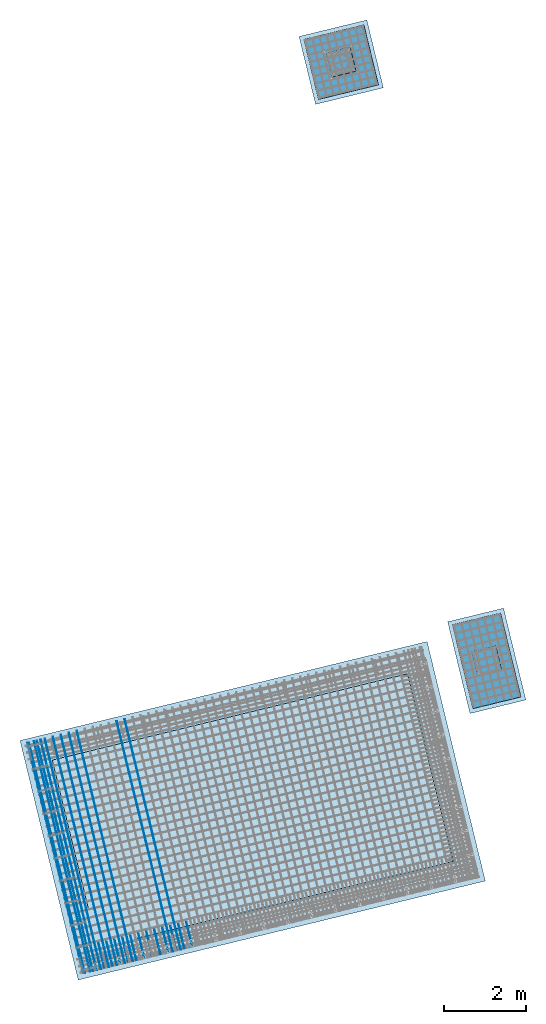
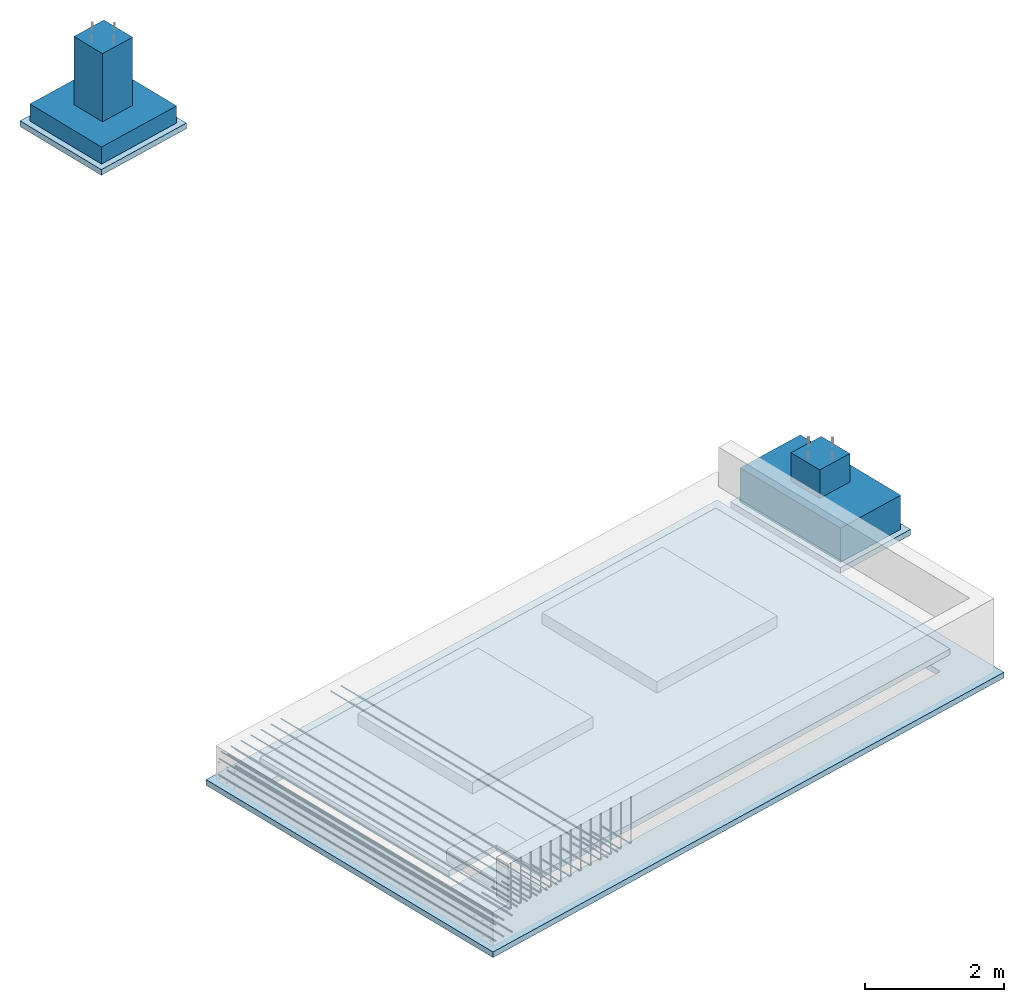
# One storey, part 1 of 24: 28 reinforcing bars, 6 slabs, 1 opening.
"""IFC2X3 building model written with IfcOpenShell, lengths in millimetres."""

from ifc_helpers import new_model, entity, si_unit, converted_unit, derived_unit, direction, frame, frame_2d, origin, origin_2d_with_axis, place, context, subcontext, project, spatial, polyline, rectangle, outline, extrude, faceted_brep, material, layer, layer_set, layer_usage, type_object, element, save


model = new_model("IFC2X3")

# Units and contexts
model_context = context("Model", 3, precision=0.01, world=origin(), true_north=direction((6.12303176911189e-17, 1.0)))
body_context = subcontext(model_context, "Body", "Model", "MODEL_VIEW")
ifc_project = project(units=[si_unit("LENGTHUNIT", "METRE", prefix="MILLI"), si_unit("AREAUNIT", "SQUARE_METRE"), si_unit("VOLUMEUNIT", "CUBIC_METRE"), converted_unit("PLANEANGLEUNIT", "DEGREE", entity("IfcRatioMeasure", 0.0174532925199433), si_unit("PLANEANGLEUNIT", "RADIAN"), dimensions=[0, 0, 0, 0, 0, 0, 0]), si_unit("MASSUNIT", "GRAM", prefix="KILO"), derived_unit("MASSDENSITYUNIT", [(si_unit("MASSUNIT", "GRAM", prefix="KILO"), 1), (si_unit("LENGTHUNIT", "METRE"), -3)]), derived_unit("MOMENTOFINERTIAUNIT", [(si_unit("LENGTHUNIT", "METRE"), 4)]), si_unit("TIMEUNIT", "SECOND"), si_unit("FREQUENCYUNIT", "HERTZ"), si_unit("THERMODYNAMICTEMPERATUREUNIT", "DEGREE_CELSIUS"), derived_unit("THERMALTRANSMITTANCEUNIT", [(si_unit("MASSUNIT", "GRAM", prefix="KILO"), 1), (si_unit("THERMODYNAMICTEMPERATUREUNIT", "KELVIN"), -1), (si_unit("TIMEUNIT", "SECOND"), -3)]), derived_unit("VOLUMETRICFLOWRATEUNIT", [(si_unit("LENGTHUNIT", "METRE"), 3), (si_unit("TIMEUNIT", "SECOND"), -1)]), derived_unit("MASSFLOWRATEUNIT", [(si_unit("MASSUNIT", "GRAM", prefix="KILO"), 1), (si_unit("TIMEUNIT", "SECOND"), -1)]), derived_unit("ROTATIONALFREQUENCYUNIT", [(si_unit("TIMEUNIT", "SECOND"), -1)]), si_unit("ELECTRICCURRENTUNIT", "AMPERE"), si_unit("ELECTRICVOLTAGEUNIT", "VOLT"), si_unit("POWERUNIT", "WATT"), si_unit("FORCEUNIT", "NEWTON", prefix="KILO"), si_unit("ILLUMINANCEUNIT", "LUX"), si_unit("LUMINOUSFLUXUNIT", "LUMEN"), si_unit("LUMINOUSINTENSITYUNIT", "CANDELA"), derived_unit("USERDEFINED", [(si_unit("MASSUNIT", "GRAM", prefix="KILO"), -1), (si_unit("LENGTHUNIT", "METRE"), -2), (si_unit("TIMEUNIT", "SECOND"), 3), (si_unit("LUMINOUSFLUXUNIT", "LUMEN"), 1)]), derived_unit("LINEARVELOCITYUNIT", [(si_unit("LENGTHUNIT", "METRE"), 1), (si_unit("TIMEUNIT", "SECOND"), -1)]), si_unit("PRESSUREUNIT", "PASCAL"), derived_unit("USERDEFINED", [(si_unit("LENGTHUNIT", "METRE"), -2), (si_unit("MASSUNIT", "GRAM", prefix="KILO"), 1), (si_unit("TIMEUNIT", "SECOND"), -2)]), derived_unit("LINEARFORCEUNIT", [(si_unit("MASSUNIT", "GRAM", prefix="KILO"), 1), (si_unit("LENGTHUNIT", "METRE"), 1), (si_unit("TIMEUNIT", "SECOND"), -2), (si_unit("LENGTHUNIT", "METRE"), -1)]), derived_unit("PLANARFORCEUNIT", [(si_unit("MASSUNIT", "GRAM", prefix="KILO"), 1), (si_unit("LENGTHUNIT", "METRE"), 1), (si_unit("TIMEUNIT", "SECOND"), -2), (si_unit("LENGTHUNIT", "METRE"), -2)])], contexts=[model_context])

# Site, building, storey
site_placement = place(None, frame((19171.75, -72498.58, 0.0), z_axis=(0.0, 0.0, 1.0), x_axis=(0.971695960795463, 0.236234967296933, 0.0)))
site = spatial("IfcSite", under=ifc_project, at=site_placement, CompositionType="ELEMENT")
building_placement = place(site_placement, origin())
building = spatial("IfcBuilding", under=site, at=building_placement, CompositionType="ELEMENT")
storey_placement = place(building_placement, origin())
storey = spatial("IfcBuildingStorey", under=building, at=storey_placement, CompositionType="ELEMENT", Elevation=0.0)

# Slab, opening
ifc_material_1 = material()
ifc_layer = layer(ifc_material_1, 100.0)
ifc_layer_set = layer_set([ifc_layer])
ifc_layer_usage = layer_usage(ifc_layer_set, "AXIS3", "POSITIVE", 0.0)
slab_type_1 = type_object("IfcSlabType", PredefinedType="BASESLAB", material=ifc_layer_set)
slab_1_placement = place(storey_placement, frame((-100.0, -100.0, -700.0)))
slab_1 = element("IfcSlab", 1, at=slab_1_placement, inside=storey, type_object=slab_type_1, material=ifc_layer_usage, PredefinedType="BASESLAB", context=body_context, shape_type="SweptSolid", body=[
    extrude(rectangle(XDim=10200.0, YDim=6000.00000000003, at=frame_2d((0.0, 0.0), x_axis=(-1.0, 0.0))), frame((5100.0, 3000.0, 100.0), z_axis=(0.0, 0.0, -1.0), x_axis=(-1.0, 0.0, 0.0)), (0.0, 0.0, 1.0), 100.0),
])
opening_placement = place(slab_1_placement, frame((3933.33, 2533.33, 100.0)))
element("IfcOpeningElement", 2, at=opening_placement, cuts=slab_1, ObjectType="Opening", context=body_context, shape_type="SweptSolid", body=[
    extrude(outline(polyline([(-933.33, 3283.33), (-933.33, 2333.33), (-1883.33, 2333.33), (-1883.33, -5616.67), (2816.67, -5616.67), (2816.67, 3283.33), (-933.33, 3283.33)])), frame((0.0, 0.0, 0.0), z_axis=(0.0, 0.0, 1.0), x_axis=(0.0, 1.0, 0.0)), (0.0, 0.0, -1.0), 100.0),
])

# Slabs
slab_type_2 = type_object("IfcSlabType", PredefinedType="BASESLAB", material=ifc_layer_set)
placement = place(storey_placement, origin())
element("IfcSlab", 3, at=placement, inside=storey, type_object=slab_type_2, material=ifc_layer_usage, PredefinedType="BASESLAB", context=body_context, shape_type="SweptSolid", body=[
    extrude(outline(polyline([(-1000.0, -3350.0), (2950.0, -3350.0), (2950.0, 5750.0), (-1950.0, 5750.0), (-1950.0, -2400.0), (-1000.0, -2400.0), (-1000.0, -3350.0)])), frame((3800.0, 2400.0, -200.0), z_axis=(0.0, 0.0, -1.0), x_axis=(0.0, 1.0, 0.0)), (0.0, 0.0, 1.0), 100.0),
])
slab_type_3 = type_object("IfcSlabType", PredefinedType="BASESLAB")
slab_3_placement = place(storey_placement, frame((10800.0, 4050.0, -1100.0)))
element("IfcSlab", 4, at=slab_3_placement, inside=storey, type_object=slab_type_3, PredefinedType="BASESLAB", context=body_context, shape_type="Brep", body=[
    faceted_brep([(300.0, 750.0, 1100.0), (900.0, 750.0, 1100.0), (900.0, 1350.0, 1100.0), (300.0, 1350.0, 1100.0), (300.0, 750.0, 600.0), (900.0, 750.0, 600.0), (900.0, 1350.0, 600.0), (300.0, 1350.0, 600.0), (0.0, 0.0, 600.0), (1200.0, 0.0, 600.0), (1200.0, 2100.0, 600.0), (0.0, 2100.0, 600.0), (0.0, 0.0, 0.0), (0.0, 2100.0, 0.0), (1200.0, 2100.0, 0.0), (1200.0, 0.0, 0.0)], [[[0, 1, 2, 3]], [[1, 0, 4, 5]], [[2, 1, 5, 6]], [[3, 2, 6, 7]], [[0, 3, 7, 4]], [[5, 4, 7, 6], [8, 9, 10, 11]], [[12, 13, 14, 15]], [[9, 8, 12, 15]], [[10, 9, 15, 14]], [[11, 10, 14, 13]], [[8, 11, 13, 12]]], outer=[[True], [True], [True], [True], [True], [False, True], [True], [True], [True], [True], [True]]),
])
slab_type_4 = type_object("IfcSlabType", PredefinedType="BASESLAB")
slab_4_placement = place(storey_placement, frame((10650.0, 19350.0, -1760.0)))
element("IfcSlab", 5, at=slab_4_placement, inside=storey, type_object=slab_type_4, PredefinedType="BASESLAB", context=body_context, shape_type="Brep", body=[
    faceted_brep([(450.0, 450.0, 1500.0), (1050.0, 450.0, 1500.0), (1050.0, 1050.0, 1500.0), (450.0, 1050.0, 1500.0), (450.0, 450.0, 300.0), (1050.0, 450.0, 300.0), (1050.0, 1050.0, 300.0), (450.0, 1050.0, 300.0), (0.0, 0.0, 300.0), (1500.0, 0.0, 300.0), (1500.0, 1500.0, 300.0), (0.0, 1500.0, 300.0), (0.0, 0.0, 0.0), (0.0, 1500.0, 0.0), (1500.0, 1500.0, 0.0), (1500.0, 0.0, 0.0)], [[[0, 1, 2, 3]], [[1, 0, 4, 5]], [[2, 1, 5, 6]], [[3, 2, 6, 7]], [[0, 3, 7, 4]], [[5, 4, 7, 6], [8, 9, 10, 11]], [[12, 13, 14, 15]], [[9, 8, 12, 15]], [[10, 9, 15, 14]], [[11, 10, 14, 13]], [[8, 11, 13, 12]]], outer=[[True], [True], [True], [True], [True], [False, True], [True], [True], [True], [True], [True]]),
])
slab_type_5 = type_object("IfcSlabType", PredefinedType="BASESLAB", material=ifc_layer_set)
element("IfcSlab", 6, at=placement, inside=storey, type_object=slab_type_5, material=ifc_layer_usage, PredefinedType="BASESLAB", context=body_context, shape_type="SweptSolid", body=[
    extrude(rectangle(XDim=2300.0, YDim=1400.0, at=origin_2d_with_axis()), frame((11400.0, 5100.0, -1100.0), z_axis=(0.0, 0.0, -1.0), x_axis=(0.0, 1.0, 0.0)), (0.0, 0.0, 1.0), 100.0),
])
slab_type_6 = type_object("IfcSlabType", PredefinedType="BASESLAB", material=ifc_layer_set)
element("IfcSlab", 7, at=placement, inside=storey, type_object=slab_type_6, material=ifc_layer_usage, PredefinedType="BASESLAB", context=body_context, shape_type="SweptSolid", body=[
    extrude(rectangle(XDim=1700.0, YDim=1700.0, at=origin_2d_with_axis()), frame((11400.0, 20100.0, -1760.0), z_axis=(0.0, 0.0, -1.0), x_axis=(0.0, 1.0, 0.0)), (0.0, 0.0, 1.0), 100.0),
])

# Reinforcing bars
ifc_material_2 = material()
element("IfcReinforcingBar", 8, at=placement, inside=storey, material=ifc_material_2, BarLength=5775.0, BarRole="NOTDEFINED", CrossSectionArea=0.0001539380400259, NominalDiameter=14.0, context=body_context, shape_type="AdvancedSweptSolid", body=[
    entity("IfcSweptDiskSolid", entity("IfcCompositeCurve", [entity("IfcCompositeCurveSegment", "CONTINUOUS", True, entity("IfcPolyline", [entity("IfcCartesianPoint", [2500.0, 5800.0, -150.0]), entity("IfcCartesianPoint", [2500.0, 25.0, -150.0])]))], False), 7.0, None, 0.0, 1.0),
])
element("IfcReinforcingBar", 9, at=placement, inside=storey, material=ifc_material_2, BarLength=5775.0, BarRole="NOTDEFINED", CrossSectionArea=0.0001539380400259, NominalDiameter=14.0, context=body_context, shape_type="AdvancedSweptSolid", body=[
    entity("IfcSweptDiskSolid", entity("IfcCompositeCurve", [entity("IfcCompositeCurveSegment", "CONTINUOUS", True, entity("IfcPolyline", [entity("IfcCartesianPoint", [2300.0, 5800.0, -150.0]), entity("IfcCartesianPoint", [2300.0, 25.0, -150.0])]))], False), 7.0, None, 0.0, 1.0),
])
element("IfcReinforcingBar", 10, at=placement, inside=storey, material=ifc_material_2, BarLength=5775.0, BarRole="NOTDEFINED", CrossSectionArea=0.0001539380400259, NominalDiameter=14.0, context=body_context, shape_type="AdvancedSweptSolid", body=[
    entity("IfcSweptDiskSolid", entity("IfcCompositeCurve", [entity("IfcCompositeCurveSegment", "CONTINUOUS", True, entity("IfcPolyline", [entity("IfcCartesianPoint", [1300.0, 5800.0, -150.0]), entity("IfcCartesianPoint", [1300.0, 25.0, -150.0])]))], False), 7.0, None, 0.0, 1.0),
])
element("IfcReinforcingBar", 11, at=placement, inside=storey, material=ifc_material_2, BarLength=5775.0, BarRole="NOTDEFINED", CrossSectionArea=0.0001539380400259, NominalDiameter=14.0, context=body_context, shape_type="AdvancedSweptSolid", body=[
    entity("IfcSweptDiskSolid", entity("IfcCompositeCurve", [entity("IfcCompositeCurveSegment", "CONTINUOUS", True, entity("IfcPolyline", [entity("IfcCartesianPoint", [1100.0, 5800.0, -150.0]), entity("IfcCartesianPoint", [1100.0, 25.0, -150.0])]))], False), 7.0, None, 0.0, 1.0),
])
element("IfcReinforcingBar", 12, at=placement, inside=storey, material=ifc_material_2, BarLength=5775.0, BarRole="NOTDEFINED", CrossSectionArea=0.0001539380400259, NominalDiameter=14.0, context=body_context, shape_type="AdvancedSweptSolid", body=[
    entity("IfcSweptDiskSolid", entity("IfcCompositeCurve", [entity("IfcCompositeCurveSegment", "CONTINUOUS", True, entity("IfcPolyline", [entity("IfcCartesianPoint", [900.0, 5800.0, -150.0]), entity("IfcCartesianPoint", [900.0, 25.0, -150.0])]))], False), 7.0, None, 0.0, 1.0),
])
element("IfcReinforcingBar", 13, at=placement, inside=storey, material=ifc_material_2, BarLength=5775.0, BarRole="NOTDEFINED", CrossSectionArea=0.0001539380400259, NominalDiameter=14.0, context=body_context, shape_type="AdvancedSweptSolid", body=[
    entity("IfcSweptDiskSolid", entity("IfcCompositeCurve", [entity("IfcCompositeCurveSegment", "CONTINUOUS", True, entity("IfcPolyline", [entity("IfcCartesianPoint", [700.0, 5800.0, -150.0]), entity("IfcCartesianPoint", [700.0, 25.0, -150.0])]))], False), 7.0, None, 0.0, 1.0),
])
element("IfcReinforcingBar", 14, at=placement, inside=storey, material=ifc_material_2, BarLength=5775.0, BarRole="NOTDEFINED", CrossSectionArea=0.0001539380400259, NominalDiameter=14.0, context=body_context, shape_type="AdvancedSweptSolid", body=[
    entity("IfcSweptDiskSolid", entity("IfcCompositeCurve", [entity("IfcCompositeCurveSegment", "CONTINUOUS", True, entity("IfcPolyline", [entity("IfcCartesianPoint", [500.0, 5800.0, -150.0]), entity("IfcCartesianPoint", [500.0, 25.0, -150.0])]))], False), 7.0, None, 0.0, 1.0),
])
element("IfcReinforcingBar", 15, at=placement, inside=storey, material=ifc_material_2, BarLength=5775.0, BarRole="NOTDEFINED", CrossSectionArea=0.0001539380400259, NominalDiameter=14.0, context=body_context, shape_type="AdvancedSweptSolid", body=[
    entity("IfcSweptDiskSolid", entity("IfcCompositeCurve", [entity("IfcCompositeCurveSegment", "CONTINUOUS", True, entity("IfcPolyline", [entity("IfcCartesianPoint", [300.0, 5800.0, -150.0]), entity("IfcCartesianPoint", [300.0, 25.0, -150.0])]))], False), 7.0, None, 0.0, 1.0),
])
element("IfcReinforcingBar", 16, at=placement, inside=storey, material=ifc_material_2, BarLength=5775.0, BarRole="NOTDEFINED", CrossSectionArea=0.0001539380400259, NominalDiameter=14.0, context=body_context, shape_type="AdvancedSweptSolid", body=[
    entity("IfcSweptDiskSolid", entity("IfcCompositeCurve", [entity("IfcCompositeCurveSegment", "CONTINUOUS", True, entity("IfcPolyline", [entity("IfcCartesianPoint", [100.0, 5800.0, -150.0]), entity("IfcCartesianPoint", [100.0, 25.0, -150.0])]))], False), 7.0, None, 0.0, 1.0),
])
element("IfcReinforcingBar", 17, at=placement, inside=storey, material=ifc_material_2, BarLength=5775.0, BarRole="NOTDEFINED", CrossSectionArea=0.0001539380400259, NominalDiameter=14.0, context=body_context, shape_type="AdvancedSweptSolid", body=[
    entity("IfcSweptDiskSolid", entity("IfcCompositeCurve", [entity("IfcCompositeCurveSegment", "CONTINUOUS", True, entity("IfcPolyline", [entity("IfcCartesianPoint", [65.69, 5800.0, -257.81]), entity("IfcCartesianPoint", [65.69, 25.0, -257.81])]))], False), 7.0, None, 0.0, 1.0),
])
element("IfcReinforcingBar", 18, at=placement, inside=storey, material=ifc_material_2, BarLength=5775.0, BarRole="NOTDEFINED", CrossSectionArea=0.0001539380400259, NominalDiameter=14.0, context=body_context, shape_type="AdvancedSweptSolid", body=[
    entity("IfcSweptDiskSolid", entity("IfcCompositeCurve", [entity("IfcCompositeCurveSegment", "CONTINUOUS", True, entity("IfcPolyline", [entity("IfcCartesianPoint", [395.69, 5800.0, -257.81]), entity("IfcCartesianPoint", [395.69, 25.0, -257.81])]))], False), 7.0, None, 0.0, 1.0),
])
element("IfcReinforcingBar", 19, at=placement, inside=storey, material=ifc_material_2, BarLength=5775.0, BarRole="NOTDEFINED", CrossSectionArea=0.0001539380400259, NominalDiameter=14.0, context=body_context, shape_type="AdvancedSweptSolid", body=[
    entity("IfcSweptDiskSolid", entity("IfcCompositeCurve", [entity("IfcCompositeCurveSegment", "CONTINUOUS", True, entity("IfcPolyline", [entity("IfcCartesianPoint", [230.69, 5800.0, -257.81]), entity("IfcCartesianPoint", [230.69, 25.0, -257.81])]))], False), 7.0, None, 0.0, 1.0),
])
element("IfcReinforcingBar", 20, at=placement, inside=storey, material=ifc_material_2, BarLength=5775.0, BarRole="NOTDEFINED", CrossSectionArea=0.0001539380400259, NominalDiameter=14.0, context=body_context, shape_type="AdvancedSweptSolid", body=[
    entity("IfcSweptDiskSolid", entity("IfcCompositeCurve", [entity("IfcCompositeCurveSegment", "CONTINUOUS", True, entity("IfcPolyline", [entity("IfcCartesianPoint", [65.69, 5800.0, -547.81]), entity("IfcCartesianPoint", [65.69, 25.0, -547.81])]))], False), 7.0, None, 0.0, 1.0),
])
element("IfcReinforcingBar", 21, at=placement, inside=storey, material=ifc_material_2, BarLength=5775.0, BarRole="NOTDEFINED", CrossSectionArea=0.0001539380400259, NominalDiameter=14.0, context=body_context, shape_type="AdvancedSweptSolid", body=[
    entity("IfcSweptDiskSolid", entity("IfcCompositeCurve", [entity("IfcCompositeCurveSegment", "CONTINUOUS", True, entity("IfcPolyline", [entity("IfcCartesianPoint", [395.69, 5800.0, -547.81]), entity("IfcCartesianPoint", [395.69, 25.0, -547.81])]))], False), 7.0, None, 0.0, 1.0),
])
element("IfcReinforcingBar", 22, at=placement, inside=storey, material=ifc_material_2, BarLength=5775.0, BarRole="NOTDEFINED", CrossSectionArea=0.0001539380400259, NominalDiameter=14.0, context=body_context, shape_type="AdvancedSweptSolid", body=[
    entity("IfcSweptDiskSolid", entity("IfcCompositeCurve", [entity("IfcCompositeCurveSegment", "CONTINUOUS", True, entity("IfcPolyline", [entity("IfcCartesianPoint", [230.69, 5800.0, -547.81]), entity("IfcCartesianPoint", [230.69, 25.0, -547.81])]))], False), 7.0, None, 0.0, 1.0),
])
element("IfcReinforcingBar", 23, at=placement, inside=storey, material=ifc_material_2, BarLength=1400.0, BarRole="NOTDEFINED", CrossSectionArea=0.0001539380400259, NominalDiameter=14.0, context=body_context, shape_type="AdvancedSweptSolid", body=[
    entity("IfcSweptDiskSolid", entity("IfcCompositeCurve", [entity("IfcCompositeCurveSegment", "CONTINUOUS", True, entity("IfcPolyline", [entity("IfcCartesianPoint", [393.15, 44.74, 655.7]), entity("IfcCartesianPoint", [393.15, 44.74, -122.3])])), entity("IfcCompositeCurveSegment", "CONTINUOUS", True, entity("IfcTrimmedCurve", entity("IfcCircle", entity("IfcAxis2Placement3D", entity("IfcCartesianPoint", [393.15, 86.74, -122.3]), entity("IfcDirection", [1.0, 0.0, 0.0]), entity("IfcDirection", [0.0, 0.0, -1.0])), 42.0), [entity("IfcParameterValue", 270.0)], [entity("IfcParameterValue", 360.0)], True, "PARAMETER")), entity("IfcCompositeCurveSegment", "CONTINUOUS", True, entity("IfcPolyline", [entity("IfcCartesianPoint", [393.15, 86.74, -164.3]), entity("IfcCartesianPoint", [393.15, 644.74, -164.3])]))], False), 7.0, None, 0.0, 92.0000000000001),
])
element("IfcReinforcingBar", 24, at=placement, inside=storey, material=ifc_material_2, BarLength=1400.0, BarRole="NOTDEFINED", CrossSectionArea=0.0001539380400259, NominalDiameter=14.0, context=body_context, shape_type="AdvancedSweptSolid", body=[
    entity("IfcSweptDiskSolid", entity("IfcCompositeCurve", [entity("IfcCompositeCurveSegment", "CONTINUOUS", True, entity("IfcPolyline", [entity("IfcCartesianPoint", [593.15, 44.74, 655.7]), entity("IfcCartesianPoint", [593.15, 44.74, -122.3])])), entity("IfcCompositeCurveSegment", "CONTINUOUS", True, entity("IfcTrimmedCurve", entity("IfcCircle", entity("IfcAxis2Placement3D", entity("IfcCartesianPoint", [593.15, 86.74, -122.3]), entity("IfcDirection", [1.0, 0.0, 0.0]), entity("IfcDirection", [0.0, 0.0, -1.0])), 42.0), [entity("IfcParameterValue", 270.0)], [entity("IfcParameterValue", 360.0)], True, "PARAMETER")), entity("IfcCompositeCurveSegment", "CONTINUOUS", True, entity("IfcPolyline", [entity("IfcCartesianPoint", [593.15, 86.74, -164.3]), entity("IfcCartesianPoint", [593.15, 644.74, -164.3])]))], False), 7.0, None, 0.0, 92.0000000000001),
])
element("IfcReinforcingBar", 25, at=placement, inside=storey, material=ifc_material_2, BarLength=1400.0, BarRole="NOTDEFINED", CrossSectionArea=0.0001539380400259, NominalDiameter=14.0, context=body_context, shape_type="AdvancedSweptSolid", body=[
    entity("IfcSweptDiskSolid", entity("IfcCompositeCurve", [entity("IfcCompositeCurveSegment", "CONTINUOUS", True, entity("IfcPolyline", [entity("IfcCartesianPoint", [793.15, 44.74, 655.7]), entity("IfcCartesianPoint", [793.15, 44.74, -122.3])])), entity("IfcCompositeCurveSegment", "CONTINUOUS", True, entity("IfcTrimmedCurve", entity("IfcCircle", entity("IfcAxis2Placement3D", entity("IfcCartesianPoint", [793.15, 86.74, -122.3]), entity("IfcDirection", [1.0, 0.0, 0.0]), entity("IfcDirection", [0.0, 0.0, -1.0])), 42.0), [entity("IfcParameterValue", 270.0)], [entity("IfcParameterValue", 360.0)], True, "PARAMETER")), entity("IfcCompositeCurveSegment", "CONTINUOUS", True, entity("IfcPolyline", [entity("IfcCartesianPoint", [793.15, 86.74, -164.3]), entity("IfcCartesianPoint", [793.15, 644.74, -164.3])]))], False), 7.0, None, 0.0, 92.0000000000001),
])
element("IfcReinforcingBar", 26, at=placement, inside=storey, material=ifc_material_2, BarLength=1400.0, BarRole="NOTDEFINED", CrossSectionArea=0.0001539380400259, NominalDiameter=14.0, context=body_context, shape_type="AdvancedSweptSolid", body=[
    entity("IfcSweptDiskSolid", entity("IfcCompositeCurve", [entity("IfcCompositeCurveSegment", "CONTINUOUS", True, entity("IfcPolyline", [entity("IfcCartesianPoint", [993.15, 44.74, 655.7]), entity("IfcCartesianPoint", [993.15, 44.74, -122.3])])), entity("IfcCompositeCurveSegment", "CONTINUOUS", True, entity("IfcTrimmedCurve", entity("IfcCircle", entity("IfcAxis2Placement3D", entity("IfcCartesianPoint", [993.15, 86.74, -122.3]), entity("IfcDirection", [1.0, 0.0, 0.0]), entity("IfcDirection", [0.0, 0.0, -1.0])), 42.0), [entity("IfcParameterValue", 270.0)], [entity("IfcParameterValue", 360.0)], True, "PARAMETER")), entity("IfcCompositeCurveSegment", "CONTINUOUS", True, entity("IfcPolyline", [entity("IfcCartesianPoint", [993.15, 86.74, -164.3]), entity("IfcCartesianPoint", [993.15, 644.74, -164.3])]))], False), 7.0, None, 0.0, 92.0000000000001),
])
element("IfcReinforcingBar", 27, at=placement, inside=storey, material=ifc_material_2, BarLength=1400.0, BarRole="NOTDEFINED", CrossSectionArea=0.0001539380400259, NominalDiameter=14.0, context=body_context, shape_type="AdvancedSweptSolid", body=[
    entity("IfcSweptDiskSolid", entity("IfcCompositeCurve", [entity("IfcCompositeCurveSegment", "CONTINUOUS", True, entity("IfcPolyline", [entity("IfcCartesianPoint", [1193.15, 44.74, 655.7]), entity("IfcCartesianPoint", [1193.15, 44.74, -122.3])])), entity("IfcCompositeCurveSegment", "CONTINUOUS", True, entity("IfcTrimmedCurve", entity("IfcCircle", entity("IfcAxis2Placement3D", entity("IfcCartesianPoint", [1193.15, 86.74, -122.3]), entity("IfcDirection", [1.0, 0.0, 0.0]), entity("IfcDirection", [0.0, 0.0, -1.0])), 42.0), [entity("IfcParameterValue", 270.0)], [entity("IfcParameterValue", 360.0)], True, "PARAMETER")), entity("IfcCompositeCurveSegment", "CONTINUOUS", True, entity("IfcPolyline", [entity("IfcCartesianPoint", [1193.15, 86.74, -164.3]), entity("IfcCartesianPoint", [1193.15, 644.74, -164.3])]))], False), 7.0, None, 0.0, 92.0000000000001),
])
element("IfcReinforcingBar", 28, at=placement, inside=storey, material=ifc_material_2, BarLength=1400.0, BarRole="NOTDEFINED", CrossSectionArea=0.0001539380400259, NominalDiameter=14.0, context=body_context, shape_type="AdvancedSweptSolid", body=[
    entity("IfcSweptDiskSolid", entity("IfcCompositeCurve", [entity("IfcCompositeCurveSegment", "CONTINUOUS", True, entity("IfcPolyline", [entity("IfcCartesianPoint", [1393.15, 44.74, 655.7]), entity("IfcCartesianPoint", [1393.15, 44.74, -122.3])])), entity("IfcCompositeCurveSegment", "CONTINUOUS", True, entity("IfcTrimmedCurve", entity("IfcCircle", entity("IfcAxis2Placement3D", entity("IfcCartesianPoint", [1393.15, 86.74, -122.3]), entity("IfcDirection", [1.0, 0.0, 0.0]), entity("IfcDirection", [0.0, 0.0, -1.0])), 42.0), [entity("IfcParameterValue", 270.0)], [entity("IfcParameterValue", 360.0)], True, "PARAMETER")), entity("IfcCompositeCurveSegment", "CONTINUOUS", True, entity("IfcPolyline", [entity("IfcCartesianPoint", [1393.15, 86.74, -164.3]), entity("IfcCartesianPoint", [1393.15, 644.74, -164.3])]))], False), 7.0, None, 0.0, 92.0000000000001),
])
element("IfcReinforcingBar", 29, at=placement, inside=storey, material=ifc_material_2, BarLength=1400.0, BarRole="NOTDEFINED", CrossSectionArea=0.0001539380400259, NominalDiameter=14.0, context=body_context, shape_type="AdvancedSweptSolid", body=[
    entity("IfcSweptDiskSolid", entity("IfcCompositeCurve", [entity("IfcCompositeCurveSegment", "CONTINUOUS", True, entity("IfcPolyline", [entity("IfcCartesianPoint", [1593.15, 44.74, 655.7]), entity("IfcCartesianPoint", [1593.15, 44.74, -122.3])])), entity("IfcCompositeCurveSegment", "CONTINUOUS", True, entity("IfcTrimmedCurve", entity("IfcCircle", entity("IfcAxis2Placement3D", entity("IfcCartesianPoint", [1593.15, 86.74, -122.3]), entity("IfcDirection", [1.0, 0.0, 0.0]), entity("IfcDirection", [0.0, 0.0, -1.0])), 42.0), [entity("IfcParameterValue", 270.0)], [entity("IfcParameterValue", 360.0)], True, "PARAMETER")), entity("IfcCompositeCurveSegment", "CONTINUOUS", True, entity("IfcPolyline", [entity("IfcCartesianPoint", [1593.15, 86.74, -164.3]), entity("IfcCartesianPoint", [1593.15, 644.74, -164.3])]))], False), 7.0, None, 0.0, 92.0000000000001),
])
element("IfcReinforcingBar", 30, at=placement, inside=storey, material=ifc_material_2, BarLength=1400.0, BarRole="NOTDEFINED", CrossSectionArea=0.0001539380400259, NominalDiameter=14.0, context=body_context, shape_type="AdvancedSweptSolid", body=[
    entity("IfcSweptDiskSolid", entity("IfcCompositeCurve", [entity("IfcCompositeCurveSegment", "CONTINUOUS", True, entity("IfcPolyline", [entity("IfcCartesianPoint", [1793.15, 44.74, 655.7]), entity("IfcCartesianPoint", [1793.15, 44.74, -122.3])])), entity("IfcCompositeCurveSegment", "CONTINUOUS", True, entity("IfcTrimmedCurve", entity("IfcCircle", entity("IfcAxis2Placement3D", entity("IfcCartesianPoint", [1793.15, 86.74, -122.3]), entity("IfcDirection", [1.0, 0.0, 0.0]), entity("IfcDirection", [0.0, 0.0, -1.0])), 42.0), [entity("IfcParameterValue", 270.0)], [entity("IfcParameterValue", 360.0)], True, "PARAMETER")), entity("IfcCompositeCurveSegment", "CONTINUOUS", True, entity("IfcPolyline", [entity("IfcCartesianPoint", [1793.15, 86.74, -164.3]), entity("IfcCartesianPoint", [1793.15, 644.74, -164.3])]))], False), 7.0, None, 0.0, 92.0000000000001),
])
element("IfcReinforcingBar", 31, at=placement, inside=storey, material=ifc_material_2, BarLength=1400.0, BarRole="NOTDEFINED", CrossSectionArea=0.0001539380400259, NominalDiameter=14.0, context=body_context, shape_type="AdvancedSweptSolid", body=[
    entity("IfcSweptDiskSolid", entity("IfcCompositeCurve", [entity("IfcCompositeCurveSegment", "CONTINUOUS", True, entity("IfcPolyline", [entity("IfcCartesianPoint", [1993.15, 44.74, 655.7]), entity("IfcCartesianPoint", [1993.15, 44.74, -122.3])])), entity("IfcCompositeCurveSegment", "CONTINUOUS", True, entity("IfcTrimmedCurve", entity("IfcCircle", entity("IfcAxis2Placement3D", entity("IfcCartesianPoint", [1993.15, 86.74, -122.3]), entity("IfcDirection", [1.0, 0.0, 0.0]), entity("IfcDirection", [0.0, 0.0, -1.0])), 42.0), [entity("IfcParameterValue", 270.0)], [entity("IfcParameterValue", 360.0)], True, "PARAMETER")), entity("IfcCompositeCurveSegment", "CONTINUOUS", True, entity("IfcPolyline", [entity("IfcCartesianPoint", [1993.15, 86.74, -164.3]), entity("IfcCartesianPoint", [1993.15, 644.74, -164.3])]))], False), 7.0, None, 0.0, 92.0000000000001),
])
element("IfcReinforcingBar", 32, at=placement, inside=storey, material=ifc_material_2, BarLength=1400.0, BarRole="NOTDEFINED", CrossSectionArea=0.0001539380400259, NominalDiameter=14.0, context=body_context, shape_type="AdvancedSweptSolid", body=[
    entity("IfcSweptDiskSolid", entity("IfcCompositeCurve", [entity("IfcCompositeCurveSegment", "CONTINUOUS", True, entity("IfcPolyline", [entity("IfcCartesianPoint", [2193.15, 44.74, 655.7]), entity("IfcCartesianPoint", [2193.15, 44.74, -122.3])])), entity("IfcCompositeCurveSegment", "CONTINUOUS", True, entity("IfcTrimmedCurve", entity("IfcCircle", entity("IfcAxis2Placement3D", entity("IfcCartesianPoint", [2193.15, 86.74, -122.3]), entity("IfcDirection", [1.0, 0.0, 0.0]), entity("IfcDirection", [0.0, 0.0, -1.0])), 42.0), [entity("IfcParameterValue", 270.0)], [entity("IfcParameterValue", 360.0)], True, "PARAMETER")), entity("IfcCompositeCurveSegment", "CONTINUOUS", True, entity("IfcPolyline", [entity("IfcCartesianPoint", [2193.15, 86.74, -164.3]), entity("IfcCartesianPoint", [2193.15, 644.74, -164.3])]))], False), 7.0, None, 0.0, 92.0000000000001),
])
element("IfcReinforcingBar", 33, at=placement, inside=storey, material=ifc_material_2, BarLength=1400.0, BarRole="NOTDEFINED", CrossSectionArea=0.0001539380400259, NominalDiameter=14.0, context=body_context, shape_type="AdvancedSweptSolid", body=[
    entity("IfcSweptDiskSolid", entity("IfcCompositeCurve", [entity("IfcCompositeCurveSegment", "CONTINUOUS", True, entity("IfcPolyline", [entity("IfcCartesianPoint", [2393.15, 44.74, 655.7]), entity("IfcCartesianPoint", [2393.15, 44.74, -122.3])])), entity("IfcCompositeCurveSegment", "CONTINUOUS", True, entity("IfcTrimmedCurve", entity("IfcCircle", entity("IfcAxis2Placement3D", entity("IfcCartesianPoint", [2393.15, 86.74, -122.3]), entity("IfcDirection", [1.0, 0.0, 0.0]), entity("IfcDirection", [0.0, 0.0, -1.0])), 42.0), [entity("IfcParameterValue", 270.0)], [entity("IfcParameterValue", 360.0)], True, "PARAMETER")), entity("IfcCompositeCurveSegment", "CONTINUOUS", True, entity("IfcPolyline", [entity("IfcCartesianPoint", [2393.15, 86.74, -164.3]), entity("IfcCartesianPoint", [2393.15, 644.74, -164.3])]))], False), 7.0, None, 0.0, 92.0000000000001),
])
element("IfcReinforcingBar", 34, at=placement, inside=storey, material=ifc_material_2, BarLength=1400.0, BarRole="NOTDEFINED", CrossSectionArea=0.0001539380400259, NominalDiameter=14.0, context=body_context, shape_type="AdvancedSweptSolid", body=[
    entity("IfcSweptDiskSolid", entity("IfcCompositeCurve", [entity("IfcCompositeCurveSegment", "CONTINUOUS", True, entity("IfcPolyline", [entity("IfcCartesianPoint", [2593.15, 44.74, 655.7]), entity("IfcCartesianPoint", [2593.15, 44.74, -122.3])])), entity("IfcCompositeCurveSegment", "CONTINUOUS", True, entity("IfcTrimmedCurve", entity("IfcCircle", entity("IfcAxis2Placement3D", entity("IfcCartesianPoint", [2593.15, 86.74, -122.3]), entity("IfcDirection", [1.0, 0.0, 0.0]), entity("IfcDirection", [0.0, 0.0, -1.0])), 42.0), [entity("IfcParameterValue", 270.0)], [entity("IfcParameterValue", 360.0)], True, "PARAMETER")), entity("IfcCompositeCurveSegment", "CONTINUOUS", True, entity("IfcPolyline", [entity("IfcCartesianPoint", [2593.15, 86.74, -164.3]), entity("IfcCartesianPoint", [2593.15, 644.74, -164.3])]))], False), 7.0, None, 0.0, 92.0000000000001),
])
element("IfcReinforcingBar", 35, at=placement, inside=storey, material=ifc_material_2, BarLength=1400.0, BarRole="NOTDEFINED", CrossSectionArea=0.0001539380400259, NominalDiameter=14.0, context=body_context, shape_type="AdvancedSweptSolid", body=[
    entity("IfcSweptDiskSolid", entity("IfcCompositeCurve", [entity("IfcCompositeCurveSegment", "CONTINUOUS", True, entity("IfcPolyline", [entity("IfcCartesianPoint", [2793.15, 44.74, 655.7]), entity("IfcCartesianPoint", [2793.15, 44.74, -122.3])])), entity("IfcCompositeCurveSegment", "CONTINUOUS", True, entity("IfcTrimmedCurve", entity("IfcCircle", entity("IfcAxis2Placement3D", entity("IfcCartesianPoint", [2793.15, 86.74, -122.3]), entity("IfcDirection", [1.0, 0.0, 0.0]), entity("IfcDirection", [0.0, 0.0, -1.0])), 42.0), [entity("IfcParameterValue", 270.0)], [entity("IfcParameterValue", 360.0)], True, "PARAMETER")), entity("IfcCompositeCurveSegment", "CONTINUOUS", True, entity("IfcPolyline", [entity("IfcCartesianPoint", [2793.15, 86.74, -164.3]), entity("IfcCartesianPoint", [2793.15, 644.74, -164.3])]))], False), 7.0, None, 0.0, 92.0000000000001),
])

save(model, "model.ifc")
